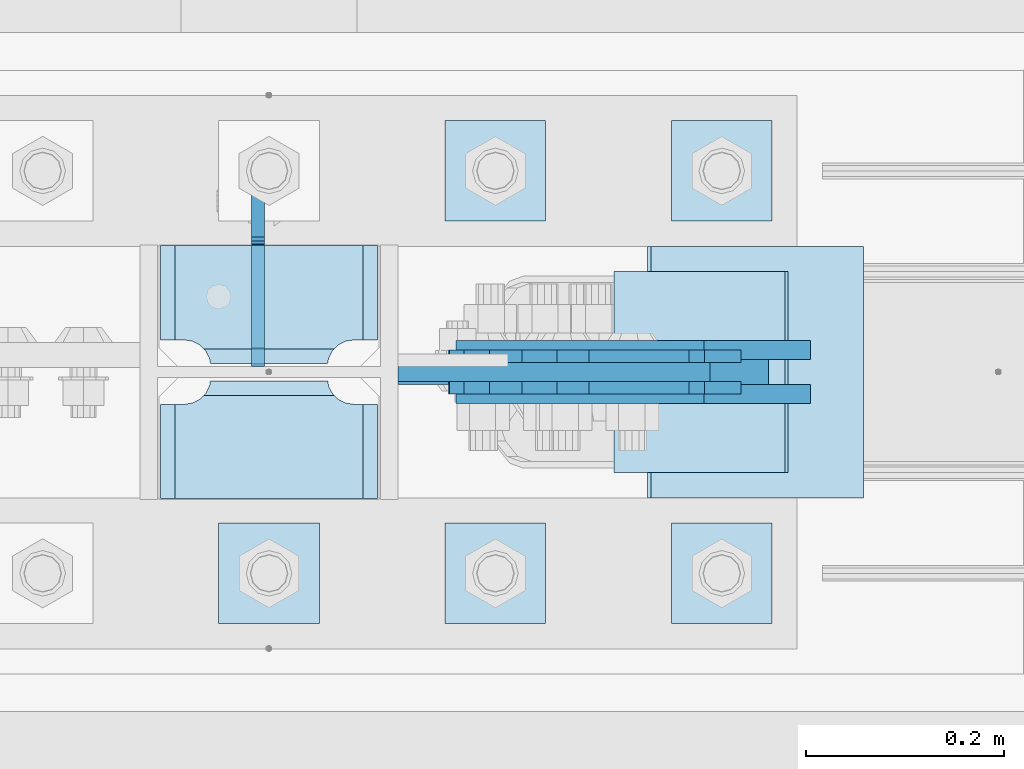
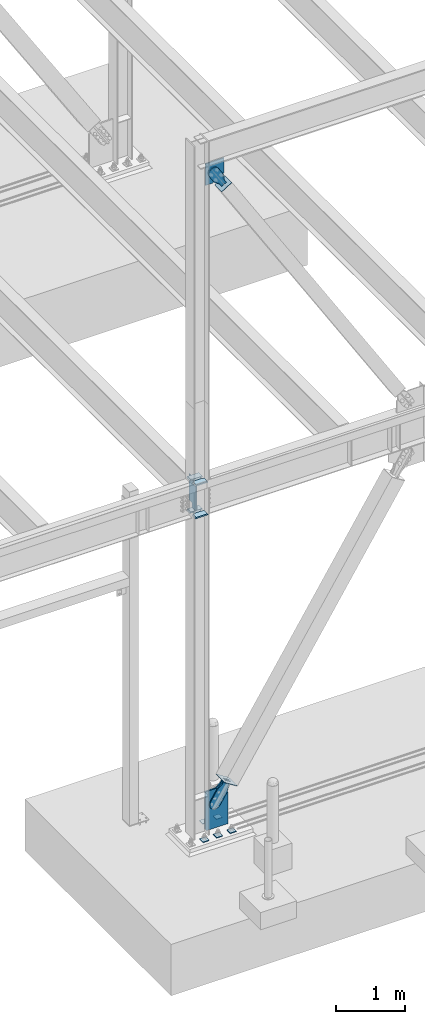
# One storey, part 3382 of 3843: 18 plates, 9 elements without a shape of their own.
"""IFC2X3 building model written with IfcOpenShell, lengths in millimetres."""

from ifc_helpers import new_model, si_unit, frame, origin_with_axes, place, context, subcontext, project, spatial, faceted_brep, material, type_object, element, aggregate, save


model = new_model("IFC2X3")

# Units and contexts
model_context = context("Model", 3, precision=1e-05, world=origin_with_axes())
body_context = subcontext(model_context, "Body", "Model", "MODEL_VIEW")
ifc_project = project(units=[si_unit("LENGTHUNIT", "METRE", prefix="MILLI"), si_unit("AREAUNIT", "SQUARE_METRE"), si_unit("VOLUMEUNIT", "CUBIC_METRE"), si_unit("MASSUNIT", "GRAM", prefix="KILO"), si_unit("TIMEUNIT", "SECOND"), si_unit("PLANEANGLEUNIT", "RADIAN"), si_unit("SOLIDANGLEUNIT", "STERADIAN"), si_unit("THERMODYNAMICTEMPERATUREUNIT", "DEGREE_CELSIUS"), si_unit("LUMINOUSINTENSITYUNIT", "LUMEN")], contexts=[model_context])

# Site, building, storey
site_placement = place(None, origin_with_axes())
site = spatial("IfcSite", under=ifc_project, at=site_placement, CompositionType="ELEMENT")
building_placement = place(site_placement, origin_with_axes())
building = spatial("IfcBuilding", under=site, at=building_placement, Name="Undefined", CompositionType="ELEMENT")
storey_placement = place(building_placement, origin_with_axes())
storey = spatial("IfcBuildingStorey", under=building, at=storey_placement, Name="Undefined", CompositionType="ELEMENT", Elevation=0.0)

# Assembly, plates
assembly_1_placement = place(storey_placement, origin_with_axes())
assembly_1 = element("IfcElementAssembly", 1, at=assembly_1_placement, inside=storey, Name="COLUMN", AssemblyPlace="NOTDEFINED", PredefinedType="RIGID_FRAME")
ifc_material_1 = material(Name="STEEL/A572-50")
plate_type_1 = type_object("IfcPlateType", PredefinedType="NOTDEFINED")
plate_1_placement = place(assembly_1_placement, frame((22972.7125, 89243.69375, 35845.75), z_axis=(-1.0, 0.0, 0.0), x_axis=(0.0, -1.0, 0.0)))
plate_1 = element("IfcPlate", 2, at=plate_1_placement, type_object=plate_type_1, material=ifc_material_1, Name="PLATE", context=body_context, shape_type="Brep", body=[
    faceted_brep([(106.374645952202, 9.2764413265686, 48.8208447555226), (104.398053430486, 12.6999999999971, 46.8442522338009), (104.398053430486, 12.6999999999971, 178.580747766202), (106.374645952201, 9.2764413265686, 176.60415524448), (113.897904100067, -3.75422402399272, 172.770863755024), (119.062750047655, -12.6999999999971, 171.952832520255), (119.062750047655, -12.6999999999971, 53.4721674797474), (113.897904100067, -3.75422402399272, 52.6541362449789), (95.2500007629424, 12.6999999999971, 17.8401965694866), (95.2500007629424, -12.6999999999971, 3.17549995231093), (0.0, -12.6999999999971, 3.17549995231093), (0.0, 12.6999999999971, 17.8401965694866), (0.0, 12.6999999999971, 207.585803430502), (0.0, -12.6999999999971, 222.250500047678), (95.2500007629424, -12.6999999999971, 222.250500047678), (95.2500007629424, 12.6999999999971, 207.585803430502), (95.2500007629424, -12.6999999999971, 198.437500762942), (95.2500007629424, 12.6999999999971, 198.437500762942), (96.5708629920846, -12.6999999999971, 190.097904863011), (96.5708629920846, 12.6999999999971, 190.097904863011), (100.404154481541, -12.6999999999971, 182.574646715148), (100.404154481541, 12.6999999999971, 182.574646715148), (106.374645952208, -12.6999999999971, 176.60415524448), (113.897904100071, -12.6999999999971, 172.770863755024), (113.897904100071, -12.6999999999971, 52.6541362449789), (106.374645952208, -12.6999999999971, 48.8208447555226), (100.404154481541, -12.6999999999971, 42.8503532848626), (100.404154481541, 12.6999999999971, 42.8503532848626), (96.5708629920846, -12.6999999999971, 35.3270951369923), (96.5708629920846, 12.6999999999971, 35.3270951369923), (95.2500007629424, -12.6999999999971, 26.9874992370605), (95.2500007629424, 12.6999999999971, 26.9874992370605)], [[[0, 1, 2, 3, 4, 5, 6, 7]], [[8, 9, 10, 11]], [[12, 13, 14, 15]], [[11, 10, 13, 12]], [[16, 17, 15, 14]], [[16, 18, 19, 17]], [[18, 20, 21, 19]], [[21, 20, 22, 3, 2]], [[22, 23, 4, 3]], [[23, 5, 4]], [[24, 7, 6]], [[24, 25, 0, 7]], [[25, 26, 27, 1, 0]], [[26, 28, 29, 27]], [[28, 30, 31, 29]], [[31, 30, 9, 8]], [[27, 29, 31, 8, 11, 12, 15, 17, 19, 21, 2, 1]], [[9, 30, 28, 26, 25, 24, 6, 5, 23, 22, 20, 18, 16, 14, 13, 10]]]),
])
plate_2_placement = place(assembly_1_placement, frame((22972.7125, 89243.69375, 36423.6), z_axis=(-1.0, 0.0, 0.0), x_axis=(0.0, -1.0, 0.0)))
plate_2 = element("IfcPlate", 3, at=plate_2_placement, type_object=plate_type_1, material=ifc_material_1, Name="PLATE", context=body_context, shape_type="Brep", body=[
    faceted_brep([(106.374645952202, 9.2764413265686, 48.8208447555226), (104.398053430486, 12.6999999999971, 46.8442522338009), (104.398053430486, 12.6999999999971, 178.580747766202), (106.374645952201, 9.2764413265686, 176.60415524448), (113.897904100067, -3.75422402399272, 172.770863755024), (119.062750047655, -12.6999999999971, 171.952832520255), (119.062750047655, -12.6999999999971, 53.4721674797474), (113.897904100067, -3.75422402399272, 52.6541362449789), (95.2500007629424, 12.6999999999971, 17.8401965694866), (95.2500007629424, -12.6999999999971, 3.17549995231093), (0.0, -12.6999999999971, 3.17549995231093), (0.0, 12.6999999999971, 17.8401965694866), (0.0, 12.6999999999971, 207.585803430502), (0.0, -12.6999999999971, 222.250500047678), (95.2500007629424, -12.6999999999971, 222.250500047678), (95.2500007629424, 12.6999999999971, 207.585803430502), (95.2500007629424, -12.6999999999971, 198.437500762942), (95.2500007629424, 12.6999999999971, 198.437500762942), (96.5708629920846, -12.6999999999971, 190.097904863011), (96.5708629920846, 12.6999999999971, 190.097904863011), (100.404154481541, -12.6999999999971, 182.574646715148), (100.404154481541, 12.6999999999971, 182.574646715148), (106.374645952208, -12.6999999999971, 176.60415524448), (113.897904100071, -12.6999999999971, 172.770863755024), (113.897904100071, -12.6999999999971, 52.6541362449789), (106.374645952208, -12.6999999999971, 48.8208447555226), (100.404154481541, -12.6999999999971, 42.8503532848626), (100.404154481541, 12.6999999999971, 42.8503532848626), (96.5708629920846, -12.6999999999971, 35.3270951369923), (96.5708629920846, 12.6999999999971, 35.3270951369923), (95.2500007629424, -12.6999999999971, 26.9874992370605), (95.2500007629424, 12.6999999999971, 26.9874992370605)], [[[0, 1, 2, 3, 4, 5, 6, 7]], [[8, 9, 10, 11]], [[12, 13, 14, 15]], [[11, 10, 13, 12]], [[16, 17, 15, 14]], [[16, 18, 19, 17]], [[18, 20, 21, 19]], [[21, 20, 22, 3, 2]], [[22, 23, 4, 3]], [[23, 5, 4]], [[24, 7, 6]], [[24, 25, 0, 7]], [[25, 26, 27, 1, 0]], [[26, 28, 29, 27]], [[28, 30, 31, 29]], [[31, 30, 9, 8]], [[27, 29, 31, 8, 11, 12, 15, 17, 19, 21, 2, 1]], [[9, 30, 28, 26, 25, 24, 6, 5, 23, 22, 20, 18, 16, 14, 13, 10]]]),
])
plate_3_placement = place(assembly_1_placement, frame((22972.7125, 89110.34375, 35845.75), z_axis=(-1.0, 0.0, 0.0), x_axis=(0.0, -1.0, 0.0)))
plate_3 = element("IfcPlate", 4, at=plate_3_placement, type_object=plate_type_1, material=ifc_material_1, Name="PLATE", context=body_context, shape_type="Brep", body=[
    faceted_brep([(15.8628540477987, 9.2764413265686, 176.60415524448), (17.8394465694582, 12.6999999999971, 178.580747766144), (17.8394465694582, 12.6999999999971, 46.8442522338592), (15.8628540477985, 9.2764413265686, 48.8208447555226), (8.33959589993262, -3.75422402399272, 52.6541362449789), (3.17474995228986, -12.6999999999971, 53.4721674797547), (3.17474995228986, -12.6999999999971, 171.952832520248), (8.33959589993288, -3.75422402399272, 172.770863755024), (122.237500000527, 12.6999999999971, 17.8401965694902), (122.23750000009, -12.6999999999971, 3.17549995231457), (26.9874992371479, -12.6999999999971, 3.17549995231457), (26.9874992375844, 12.6999999999971, 17.8401965694902), (26.9874992430996, 12.6999999999971, 207.585803430506), (26.9874992435361, -12.6999999999971, 222.250500047681), (122.237500006479, -12.6999999999971, 222.250500047681), (122.237500006042, 12.6999999999971, 207.585803430506), (8.33959589993174, -12.6999999999971, 172.770863755024), (15.8628540477948, -12.6999999999971, 176.60415524448), (21.833345518462, -12.6999999999971, 182.574646715148), (21.833345518462, 12.6999999999971, 182.574646715148), (25.6666370079183, -12.6999999999971, 190.097904863011), (25.6666370079183, 12.6999999999971, 190.097904863011), (26.9874992370605, -12.6999999999971, 198.437500762942), (26.9874992370605, 12.6999999999971, 198.437500762942), (26.9874992370605, -12.6999999999971, 26.9874992370605), (26.9874992370605, 12.6999999999971, 26.9874992370605), (25.6666370079183, -12.6999999999971, 35.3270951369923), (25.6666370079183, 12.6999999999971, 35.3270951369923), (21.833345518462, -12.6999999999971, 42.8503532848626), (21.833345518462, 12.6999999999971, 42.8503532848626), (15.8628540477948, -12.6999999999971, 48.8208447555226), (8.33959589993174, -12.6999999999971, 52.6541362449789)], [[[0, 1, 2, 3, 4, 5, 6, 7]], [[8, 9, 10, 11]], [[12, 13, 14, 15]], [[16, 7, 6]], [[16, 17, 0, 7]], [[17, 18, 19, 1, 0]], [[18, 20, 21, 19]], [[20, 22, 23, 21]], [[23, 22, 13, 12]], [[9, 8, 15, 14]], [[24, 25, 11, 10]], [[24, 26, 27, 25]], [[26, 28, 29, 27]], [[29, 28, 30, 3, 2]], [[30, 31, 4, 3]], [[31, 5, 4]], [[19, 21, 23, 12, 15, 8, 11, 25, 27, 29, 2, 1]], [[31, 30, 28, 26, 24, 10, 9, 14, 13, 22, 20, 18, 17, 16, 6, 5]]]),
])
plate_4_placement = place(assembly_1_placement, frame((22972.7125, 89110.34375, 36423.6), z_axis=(-1.0, 0.0, 0.0), x_axis=(0.0, -1.0, 0.0)))
plate_4 = element("IfcPlate", 5, at=plate_4_placement, type_object=plate_type_1, material=ifc_material_1, Name="PLATE", context=body_context, shape_type="Brep", body=[
    faceted_brep([(15.8628540477987, 9.2764413265686, 176.60415524448), (17.8394465694582, 12.6999999999971, 178.580747766144), (17.8394465694582, 12.6999999999971, 46.8442522338592), (15.8628540477985, 9.2764413265686, 48.8208447555226), (8.33959589993262, -3.75422402399272, 52.6541362449789), (3.17474995228986, -12.6999999999971, 53.4721674797547), (3.17474995228986, -12.6999999999971, 171.952832520248), (8.33959589993288, -3.75422402399272, 172.770863755024), (122.237500000527, 12.6999999999971, 17.8401965694902), (122.23750000009, -12.6999999999971, 3.17549995231457), (26.9874992371479, -12.6999999999971, 3.17549995231457), (26.9874992375844, 12.6999999999971, 17.8401965694902), (26.9874992430996, 12.6999999999971, 207.585803430506), (26.9874992435361, -12.6999999999971, 222.250500047681), (122.237500006479, -12.6999999999971, 222.250500047681), (122.237500006042, 12.6999999999971, 207.585803430506), (8.33959589993174, -12.6999999999971, 172.770863755024), (15.8628540477948, -12.6999999999971, 176.60415524448), (21.833345518462, -12.6999999999971, 182.574646715148), (21.833345518462, 12.6999999999971, 182.574646715148), (25.6666370079183, -12.6999999999971, 190.097904863011), (25.6666370079183, 12.6999999999971, 190.097904863011), (26.9874992370605, -12.6999999999971, 198.437500762942), (26.9874992370605, 12.6999999999971, 198.437500762942), (26.9874992370605, -12.6999999999971, 26.9874992370605), (26.9874992370605, 12.6999999999971, 26.9874992370605), (25.6666370079183, -12.6999999999971, 35.3270951369923), (25.6666370079183, 12.6999999999971, 35.3270951369923), (21.833345518462, -12.6999999999971, 42.8503532848626), (21.833345518462, 12.6999999999971, 42.8503532848626), (15.8628540477948, -12.6999999999971, 48.8208447555226), (8.33959589993174, -12.6999999999971, 52.6541362449789)], [[[0, 1, 2, 3, 4, 5, 6, 7]], [[8, 9, 10, 11]], [[12, 13, 14, 15]], [[16, 7, 6]], [[16, 17, 0, 7]], [[17, 18, 19, 1, 0]], [[18, 20, 21, 19]], [[20, 22, 23, 21]], [[23, 22, 13, 12]], [[9, 8, 15, 14]], [[24, 25, 11, 10]], [[24, 26, 27, 25]], [[26, 28, 29, 27]], [[29, 28, 30, 3, 2]], [[30, 31, 4, 3]], [[31, 5, 4]], [[19, 21, 23, 12, 15, 8, 11, 25, 27, 29, 2, 1]], [[31, 30, 28, 26, 24, 10, 9, 14, 13, 22, 20, 18, 17, 16, 6, 5]]]),
])

# Assembly, plate
assembly_2_placement = place(storey_placement, origin_with_axes())
assembly_2 = element("IfcElementAssembly", 6, at=assembly_2_placement, inside=storey, Name="CB", AssemblyPlace="NOTDEFINED", PredefinedType="RIGID_FRAME")
plate_type_2 = type_object("IfcPlateType", PredefinedType="NOTDEFINED")
plate_5_placement = place(assembly_2_placement, frame((23305.4642531047, 89115.9, 42002.075), z_axis=(0.0, 0.0, -1.0), x_axis=(-1.0, 0.0, 0.0)))
plate_5 = element("IfcPlate", 7, at=plate_5_placement, type_object=plate_type_2, material=ifc_material_1, Name="CB", context=body_context, shape_type="Brep", body=[
    faceted_brep([(0.0, -9.52500000000146, 0.0), (0.0, -9.52500000174041, 261.15819008874), (0.0, 9.52499999824795, 261.15819008874), (0.0, 9.52500000000146, 0.0), (196.587902692983, -9.52500000254076, 383.929714229205), (196.587902692983, 9.52499999746215, 383.929714229205), (315.289254935127, -9.52500000254076, 383.929714229205), (315.289254935127, 9.52499999746215, 383.929714229205), (315.289254935127, -9.52500000002328, -7.27595761418343e-12), (315.289254935127, 9.52499999996508, -7.27595761418343e-12)], [[[0, 1, 2, 3]], [[1, 4, 5, 2]], [[4, 6, 7, 5]], [[6, 8, 9, 7]], [[8, 0, 3, 9]], [[5, 7, 9, 3, 2]], [[8, 6, 4, 1, 0]]]),
])
aggregate(assembly_2, [plate_5])

assembly_3_placement = place(storey_placement, origin_with_axes())
assembly_3 = element("IfcElementAssembly", 8, at=assembly_3_placement, inside=storey, AssemblyPlace="NOTDEFINED", PredefinedType="RIGID_FRAME")
ifc_material_2 = material(Name="STEEL/A36")
plate_type_3 = type_object("IfcPlateType", PredefinedType="NOTDEFINED")
plate_6_placement = place(assembly_3_placement, frame((23299.8342060065, 89131.7750061035, 41617.6154840331), z_axis=(-0.848184242014813, 0.0, -0.529701323009256), x_axis=(0.529701323009257, 0.0, -0.848184242014813)))
plate_6 = element("IfcPlate", 9, at=plate_6_placement, type_object=plate_type_3, material=ifc_material_2, context=body_context, shape_type="Brep", body=[
    faceted_brep([(0.0, -6.3499999046162, 0.0), (-101.599999999482, -6.35000000000582, -44.6881937832222), (-101.599999999482, 6.35000000000582, -44.6881937832222), (7.27595761418343e-12, 6.3499999046162, 0.0), (-246.684985846376, -6.35000000000582, -44.6881937832586), (-246.684985846376, 6.35000000000582, -44.6881937832586), (-281.313054100305, -6.35000000000582, -37.8002427490646), (-281.313054100305, 6.35000000000582, -37.8002427490646), (-310.669312866783, -6.35000000000582, -18.18501775197), (-310.669312866783, 6.35000000000582, -18.18501775197), (-330.284537863758, -6.35000000000582, 11.1712410146756), (-330.284537863758, 6.35000000000582, 11.1712410146756), (-337.172488897893, -6.35000000000582, 45.7993031645856), (-337.172488897893, 6.35000000000582, 45.7993031645856), (-330.284537863699, -6.35000000000582, 80.4273714186893), (-330.284537863699, 6.35000000000582, 80.4273714186893), (-310.669312866681, -6.35000000000582, 109.783630185331), (-310.669312866681, 6.35000000000582, 109.783630185331), (-281.313054100174, -6.35000000000582, 129.39885518244), (-281.313054100174, 6.35000000000582, 129.39885518244), (-246.684988898312, -6.35000000000582, 136.286806216667), (-246.684988898312, 6.35000000000582, 136.286806216667), (-101.599999999322, -6.35000000000582, 136.286806216689), (-101.599999999322, 6.35000000000582, 136.286806216689), (2.18278728425503e-10, -6.35000000000582, 91.5986124321353), (2.18278728425503e-10, 6.35000000000582, 91.5986124321353), (69.8499999987471, -6.35000000000582, 91.598612432037), (69.8499999987471, 6.35000000000582, 91.598612432037), (69.8499999985434, -6.35000000000582, -8.73114913702011e-11), (69.8499999985434, 6.35000000000582, -8.73114913702011e-11)], [[[0, 1, 2, 3]], [[1, 4, 5, 2]], [[4, 6, 7, 5]], [[6, 8, 9, 7]], [[8, 10, 11, 9]], [[10, 12, 13, 11]], [[12, 14, 15, 13]], [[14, 16, 17, 15]], [[16, 18, 19, 17]], [[18, 20, 21, 19]], [[20, 22, 23, 21]], [[22, 24, 25, 23]], [[24, 26, 27, 25]], [[26, 28, 29, 27]], [[28, 0, 3, 29]], [[5, 7, 9, 11, 13, 15, 17, 19, 21, 23, 25, 27, 29, 3, 2]], [[28, 26, 24, 22, 20, 18, 16, 14, 12, 10, 8, 6, 4, 1, 0]]]),
])
aggregate(assembly_3, [plate_6])

assembly_4_placement = place(storey_placement, origin_with_axes())
assembly_4 = element("IfcElementAssembly", 10, at=assembly_4_placement, inside=storey, AssemblyPlace="NOTDEFINED", PredefinedType="RIGID_FRAME")
plate_7_placement = place(assembly_4_placement, frame((23299.8342060065, 89100.0250061035, 41617.6154840331), z_axis=(-0.848184242014813, 0.0, -0.529701323009256), x_axis=(0.529701323009257, 0.0, -0.848184242014813)))
plate_7 = element("IfcPlate", 11, at=plate_7_placement, type_object=plate_type_3, material=ifc_material_2, context=body_context, shape_type="Brep", body=[
    faceted_brep([(0.0, -6.3499999046162, 0.0), (-101.599999999482, -6.35000000000582, -44.6881937832222), (-101.599999999482, 6.35000000000582, -44.6881937832222), (7.27595761418343e-12, 6.3499999046162, 0.0), (-246.684985846376, -6.35000000000582, -44.6881937832586), (-246.684985846376, 6.35000000000582, -44.6881937832586), (-281.313054100305, -6.35000000000582, -37.8002427490646), (-281.313054100305, 6.35000000000582, -37.8002427490646), (-310.669312866783, -6.35000000000582, -18.18501775197), (-310.669312866783, 6.35000000000582, -18.18501775197), (-330.284537863758, -6.35000000000582, 11.1712410146756), (-330.284537863758, 6.35000000000582, 11.1712410146756), (-337.172488897893, -6.35000000000582, 45.7993031645856), (-337.172488897893, 6.35000000000582, 45.7993031645856), (-330.284537863699, -6.35000000000582, 80.4273714186893), (-330.284537863699, 6.35000000000582, 80.4273714186893), (-310.669312866681, -6.35000000000582, 109.783630185331), (-310.669312866681, 6.35000000000582, 109.783630185331), (-281.313054100174, -6.35000000000582, 129.39885518244), (-281.313054100174, 6.35000000000582, 129.39885518244), (-246.684988898312, -6.35000000000582, 136.286806216667), (-246.684988898312, 6.35000000000582, 136.286806216667), (-101.599999999322, -6.35000000000582, 136.286806216689), (-101.599999999322, 6.35000000000582, 136.286806216689), (2.18278728425503e-10, -6.35000000000582, 91.5986124321353), (2.18278728425503e-10, 6.35000000000582, 91.5986124321353), (69.8499999987471, -6.35000000000582, 91.598612432037), (69.8499999987471, 6.35000000000582, 91.598612432037), (69.8499999985434, -6.35000000000582, -8.73114913702011e-11), (69.8499999985434, 6.35000000000582, -8.73114913702011e-11)], [[[0, 1, 2, 3]], [[1, 4, 5, 2]], [[4, 6, 7, 5]], [[6, 8, 9, 7]], [[8, 10, 11, 9]], [[10, 12, 13, 11]], [[12, 14, 15, 13]], [[14, 16, 17, 15]], [[16, 18, 19, 17]], [[18, 20, 21, 19]], [[20, 22, 23, 21]], [[22, 24, 25, 23]], [[24, 26, 27, 25]], [[26, 28, 29, 27]], [[28, 0, 3, 29]], [[5, 7, 9, 11, 13, 15, 17, 19, 21, 23, 25, 27, 29, 3, 2]], [[28, 26, 24, 22, 20, 18, 16, 14, 12, 10, 8, 6, 4, 1, 0]]]),
])
aggregate(assembly_4, [plate_7])

assembly_5_placement = place(storey_placement, origin_with_axes())
assembly_5 = element("IfcElementAssembly", 12, at=assembly_5_placement, inside=storey, Name="Plate", AssemblyPlace="NOTDEFINED", PredefinedType="RIGID_FRAME")
plate_type_4 = type_object("IfcPlateType", PredefinedType="NOTDEFINED")
plate_8_placement = place(assembly_5_placement, frame((23210.1302731824, 89217.5000061035, 41482.9851923614), z_axis=(0.848184242014813, 0.0, 0.529701323009256), x_axis=(0.0, -1.0, 0.0)))
plate_8 = element("IfcPlate", 13, at=plate_8_placement, type_object=plate_type_4, material=ifc_material_2, Name="Plate", context=body_context, shape_type="Brep", body=[
    faceted_brep([(0.0, -3.17499999999927, 0.0), (0.0, -3.17500000043947, 203.200000001736), (0.0, 3.1749999995518, 203.200000001743), (0.0, 3.17499999999927, 0.0), (203.200000000012, -3.17500000043947, 203.200000001736), (203.200000000012, 3.1749999995518, 203.200000001743), (203.199996948242, -3.17499999999927, 0.0), (203.199996948242, 3.17499999999927, 0.0)], [[[0, 1, 2, 3]], [[1, 4, 5, 2]], [[4, 6, 7, 5]], [[6, 0, 3, 7]], [[5, 7, 3, 2]], [[6, 4, 1, 0]]]),
])
aggregate(assembly_5, [plate_8])

# Assembly, plates
assembly_6_placement = place(storey_placement, origin_with_axes())
assembly_6 = element("IfcElementAssembly", 14, at=assembly_6_placement, inside=storey, Name="TEMPLATE", AssemblyPlace="NOTDEFINED", PredefinedType="RIGID_FRAME")
plate_type_5 = type_object("IfcPlateType", PredefinedType="NOTDEFINED")
plate_9_placement = place(assembly_6_placement, frame((23266.4, 88963.5, 30130.75), z_axis=(0.0, -1.0, 0.0), x_axis=(1.0, 0.0, 0.0)))
plate_9 = element("IfcPlate", 15, at=plate_9_placement, type_object=plate_type_5, material=ifc_material_1, Name="Washer Plate", context=body_context, shape_type="Brep", body=[
    faceted_brep([(0.0, -6.3499999046162, 0.0), (-1.67347025126219e-10, -6.35000000000582, 101.600000000151), (-1.67347025126219e-10, 6.35000000000582, 101.600000000151), (7.27595761418343e-12, 6.3499999046162, 0.0), (101.599998474121, -6.34999999999854, 101.599998474121), (101.599998474121, 6.34999999999854, 101.599998474121), (101.6, -6.34999999999854, 0.0), (101.6, 6.34999999999854, 0.0)], [[[0, 1, 2, 3]], [[1, 4, 5, 2]], [[4, 6, 7, 5]], [[6, 0, 3, 7]], [[5, 7, 3, 2]], [[6, 4, 1, 0]]]),
])
plate_10_placement = place(assembly_6_placement, frame((23266.4, 89369.9, 30130.75), z_axis=(0.0, -1.0, 0.0), x_axis=(1.0, 0.0, 0.0)))
plate_10 = element("IfcPlate", 16, at=plate_10_placement, type_object=plate_type_5, material=ifc_material_1, Name="Washer Plate", context=body_context, shape_type="Brep", body=[
    faceted_brep([(0.0, -6.3499999046162, 0.0), (-1.67347025126219e-10, -6.35000000000582, 101.600000000151), (-1.67347025126219e-10, 6.35000000000582, 101.600000000151), (7.27595761418343e-12, 6.3499999046162, 0.0), (101.599998474121, -6.34999999999854, 101.599998474121), (101.599998474121, 6.34999999999854, 101.599998474121), (101.6, -6.34999999999854, 0.0), (101.6, 6.34999999999854, 0.0)], [[[0, 1, 2, 3]], [[1, 4, 5, 2]], [[4, 6, 7, 5]], [[6, 0, 3, 7]], [[5, 7, 3, 2]], [[6, 4, 1, 0]]]),
])
plate_11_placement = place(assembly_6_placement, frame((23037.8, 88963.5, 30130.75), z_axis=(0.0, -1.0, 0.0), x_axis=(1.0, 0.0, 0.0)))
plate_11 = element("IfcPlate", 17, at=plate_11_placement, type_object=plate_type_5, material=ifc_material_1, Name="Washer Plate", context=body_context, shape_type="Brep", body=[
    faceted_brep([(0.0, -6.3499999046162, 0.0), (-1.67347025126219e-10, -6.35000000000582, 101.600000000151), (-1.67347025126219e-10, 6.35000000000582, 101.600000000151), (7.27595761418343e-12, 6.3499999046162, 0.0), (101.599998474121, -6.34999999999854, 101.599998474121), (101.599998474121, 6.34999999999854, 101.599998474121), (101.6, -6.34999999999854, 0.0), (101.6, 6.34999999999854, 0.0)], [[[0, 1, 2, 3]], [[1, 4, 5, 2]], [[4, 6, 7, 5]], [[6, 0, 3, 7]], [[5, 7, 3, 2]], [[6, 4, 1, 0]]]),
])
plate_12_placement = place(assembly_6_placement, frame((23037.8, 89369.9, 30130.75), z_axis=(0.0, -1.0, 0.0), x_axis=(1.0, 0.0, 0.0)))
plate_12 = element("IfcPlate", 18, at=plate_12_placement, type_object=plate_type_5, material=ifc_material_1, Name="Washer Plate", context=body_context, shape_type="Brep", body=[
    faceted_brep([(0.0, -6.3499999046162, 0.0), (-1.67347025126219e-10, -6.35000000000582, 101.600000000151), (-1.67347025126219e-10, 6.35000000000582, 101.600000000151), (7.27595761418343e-12, 6.3499999046162, 0.0), (101.599998474121, -6.34999999999854, 101.599998474121), (101.599998474121, 6.34999999999854, 101.599998474121), (101.6, -6.34999999999854, 0.0), (101.6, 6.34999999999854, 0.0)], [[[0, 1, 2, 3]], [[1, 4, 5, 2]], [[4, 6, 7, 5]], [[6, 0, 3, 7]], [[5, 7, 3, 2]], [[6, 4, 1, 0]]]),
])
plate_13_placement = place(assembly_6_placement, frame((22809.2, 88963.5, 30130.75), z_axis=(0.0, -1.0, 0.0), x_axis=(1.0, 0.0, 0.0)))
plate_13 = element("IfcPlate", 19, at=plate_13_placement, type_object=plate_type_5, material=ifc_material_1, Name="Washer Plate", context=body_context, shape_type="Brep", body=[
    faceted_brep([(0.0, -6.3499999046162, 0.0), (-1.67347025126219e-10, -6.35000000000582, 101.600000000151), (-1.67347025126219e-10, 6.35000000000582, 101.600000000151), (7.27595761418343e-12, 6.3499999046162, 0.0), (101.599998474121, -6.34999999999854, 101.599998474121), (101.599998474121, 6.34999999999854, 101.599998474121), (101.6, -6.34999999999854, 0.0), (101.6, 6.34999999999854, 0.0)], [[[0, 1, 2, 3]], [[1, 4, 5, 2]], [[4, 6, 7, 5]], [[6, 0, 3, 7]], [[5, 7, 3, 2]], [[6, 4, 1, 0]]]),
])
aggregate(assembly_6, [plate_9, plate_10, plate_11, plate_12, plate_13])

# Plate
plate_type_6 = type_object("IfcPlateType", PredefinedType="NOTDEFINED")
plate_14_placement = place(assembly_1_placement, frame((22990.175, 89115.9, 30124.4), z_axis=(0.0, 0.0, 1.0), x_axis=(1.0, 0.0, 0.0)))
plate_14 = element("IfcPlate", 20, at=plate_14_placement, type_object=plate_type_6, material=ifc_material_1, Name="CB", context=body_context, shape_type="Brep", body=[
    faceted_brep([(0.0, -12.6999999999971, 19.0499992370605), (0.0, -12.6999999999971, 698.302890680108), (0.0, 12.6999999999971, 698.302890680108), (0.0, 12.6999999999971, 19.0499992370605), (167.760511938497, -12.6999999999971, 698.302890680108), (167.760511938497, 12.6999999999971, 698.302890680108), (374.243401923715, -12.6999999999971, 567.410408969536), (374.243401923715, 12.6999999999971, 567.410408969536), (374.243401923715, -12.6999999999971, 0.0), (374.243401923715, 12.6999999999971, 0.0), (19.0500015258731, -12.6999999999971, -6.33008312433958e-10), (19.0500015258731, 12.6999999999971, 0.0)], [[[0, 1, 2, 3]], [[1, 4, 5, 2]], [[4, 6, 7, 5]], [[6, 8, 9, 7]], [[8, 10, 11, 9]], [[10, 0, 3, 11]], [[5, 7, 9, 11, 3, 2]], [[10, 8, 6, 4, 1, 0]]]),
])

# Assembly, plate
assembly_7_placement = place(storey_placement, origin_with_axes())
assembly_7 = element("IfcElementAssembly", 21, at=assembly_7_placement, inside=storey, AssemblyPlace="NOTDEFINED", PredefinedType="RIGID_FRAME")
plate_type_7 = type_object("IfcPlateType", PredefinedType="NOTDEFINED")
plate_15_placement = place(assembly_7_placement, frame((23369.2169246553, 89138.1250061035, 30809.0625911752), z_axis=(-0.844597156660866, 0.0, 0.535402318785024), x_axis=(0.535402318785024, 0.0, 0.844597156660866)))
plate_15 = element("IfcPlate", 22, at=plate_15_placement, type_object=plate_type_7, material=ifc_material_2, context=body_context, shape_type="Brep", body=[
    faceted_brep([(0.0, -9.52500000000146, 0.0), (-101.599999996755, -9.52499999999418, -33.324272213511), (-101.599999996755, 9.52499999999418, -33.324272213511), (0.0, 9.52500000000146, 0.0), (-320.279297653902, -9.52499999999418, -33.3242722122595), (-320.279297653902, 9.52499999999418, -33.3242722122595), (-357.337405119242, -9.52499999999418, -25.9529563255783), (-357.337405119242, 9.52499999999418, -25.9529563255783), (-388.753751655597, -9.52499999999418, -4.96122468852991), (-388.753751655597, 9.52499999999418, -4.96122468852991), (-409.745483292782, -9.52499999999418, 26.4551218477136), (-409.745483292782, 9.52499999999418, 26.4551218477136), (-417.116799179586, -9.52499999999418, 63.5132262653569), (-417.116799179586, 9.52499999999418, 63.5132262653569), (-409.745483293211, -9.52499999999418, 100.57133373119), (-409.745483293211, 9.52499999999418, 100.57133373119), (-388.753751656006, -9.52499999999418, 131.987680267928), (-388.753751656006, 9.52499999999418, 131.987680267928), (-357.337405119271, -9.52499999999418, 152.97941190518), (-357.337405119271, 9.52499999999418, 152.97941190518), (-320.279299183247, -9.52499999999418, 160.350727791658), (-320.279299183247, 9.52499999999418, 160.350727791658), (-101.599999998418, -9.52499999999418, 160.350727790414), (-101.599999998418, 9.52499999999418, 160.350727790414), (-1.04046193882823e-09, -9.52499999999418, 127.02645557576), (-1.04046193882823e-09, 9.52499999999418, 127.02645557576), (69.8499999968899, -9.52499999999418, 127.026455575353), (69.8499999968899, 9.52499999999418, 127.026455575353), (69.8499999979995, -9.52499999999418, -4.00177668780088e-10), (69.8499999979995, 9.52499999999418, -4.00177668780088e-10)], [[[0, 1, 2, 3]], [[1, 4, 5, 2]], [[4, 6, 7, 5]], [[6, 8, 9, 7]], [[8, 10, 11, 9]], [[10, 12, 13, 11]], [[12, 14, 15, 13]], [[14, 16, 17, 15]], [[16, 18, 19, 17]], [[18, 20, 21, 19]], [[20, 22, 23, 21]], [[22, 24, 25, 23]], [[24, 26, 27, 25]], [[26, 28, 29, 27]], [[28, 0, 3, 29]], [[5, 7, 9, 11, 13, 15, 17, 19, 21, 23, 25, 27, 29, 3, 2]], [[28, 26, 24, 22, 20, 18, 16, 14, 12, 10, 8, 6, 4, 1, 0]]]),
])
aggregate(assembly_7, [plate_15])

assembly_8_placement = place(storey_placement, origin_with_axes())
assembly_8 = element("IfcElementAssembly", 23, at=assembly_8_placement, inside=storey, AssemblyPlace="NOTDEFINED", PredefinedType="RIGID_FRAME")
plate_16_placement = place(assembly_8_placement, frame((23369.2169246553, 89093.6750061035, 30809.0625911752), z_axis=(-0.844597156660866, 0.0, 0.535402318785024), x_axis=(0.535402318785024, 0.0, 0.844597156660866)))
plate_16 = element("IfcPlate", 24, at=plate_16_placement, type_object=plate_type_7, material=ifc_material_2, context=body_context, shape_type="Brep", body=[
    faceted_brep([(0.0, -9.52500000000146, 0.0), (-101.599999996755, -9.52499999999418, -33.324272213511), (-101.599999996755, 9.52499999999418, -33.324272213511), (0.0, 9.52500000000146, 0.0), (-320.279297653902, -9.52499999999418, -33.3242722122595), (-320.279297653902, 9.52499999999418, -33.3242722122595), (-357.337405119242, -9.52499999999418, -25.9529563255783), (-357.337405119242, 9.52499999999418, -25.9529563255783), (-388.753751655597, -9.52499999999418, -4.96122468852991), (-388.753751655597, 9.52499999999418, -4.96122468852991), (-409.745483292782, -9.52499999999418, 26.4551218477136), (-409.745483292782, 9.52499999999418, 26.4551218477136), (-417.116799179586, -9.52499999999418, 63.5132262653569), (-417.116799179586, 9.52499999999418, 63.5132262653569), (-409.745483293211, -9.52499999999418, 100.57133373119), (-409.745483293211, 9.52499999999418, 100.57133373119), (-388.753751656006, -9.52499999999418, 131.987680267928), (-388.753751656006, 9.52499999999418, 131.987680267928), (-357.337405119271, -9.52499999999418, 152.97941190518), (-357.337405119271, 9.52499999999418, 152.97941190518), (-320.279299183247, -9.52499999999418, 160.350727791658), (-320.279299183247, 9.52499999999418, 160.350727791658), (-101.599999998418, -9.52499999999418, 160.350727790414), (-101.599999998418, 9.52499999999418, 160.350727790414), (-1.04046193882823e-09, -9.52499999999418, 127.02645557576), (-1.04046193882823e-09, 9.52499999999418, 127.02645557576), (69.8499999968899, -9.52499999999418, 127.026455575353), (69.8499999968899, 9.52499999999418, 127.026455575353), (69.8499999979995, -9.52499999999418, -4.00177668780088e-10), (69.8499999979995, 9.52499999999418, -4.00177668780088e-10)], [[[0, 1, 2, 3]], [[1, 4, 5, 2]], [[4, 6, 7, 5]], [[6, 8, 9, 7]], [[8, 10, 11, 9]], [[10, 12, 13, 11]], [[12, 14, 15, 13]], [[14, 16, 17, 15]], [[16, 18, 19, 17]], [[18, 20, 21, 19]], [[20, 22, 23, 21]], [[22, 24, 25, 23]], [[24, 26, 27, 25]], [[26, 28, 29, 27]], [[28, 0, 3, 29]], [[5, 7, 9, 11, 13, 15, 17, 19, 21, 23, 25, 27, 29, 3, 2]], [[28, 26, 24, 22, 20, 18, 16, 14, 12, 10, 8, 6, 4, 1, 0]]]),
])
aggregate(assembly_8, [plate_16])

assembly_9_placement = place(storey_placement, origin_with_axes())
assembly_9 = element("IfcElementAssembly", 25, at=assembly_9_placement, inside=storey, Name="Plate", AssemblyPlace="NOTDEFINED", PredefinedType="RIGID_FRAME")
plate_type_8 = type_object("IfcPlateType", PredefinedType="NOTDEFINED")
plate_17_placement = place(assembly_9_placement, frame((23458.5356214929, 88988.9000061035, 30831.3851415845), z_axis=(-0.844597156660866, 0.0, 0.535402318785024), x_axis=(0.0, 1.0, 0.0)))
plate_17 = element("IfcPlate", 26, at=plate_17_placement, type_object=plate_type_8, material=ifc_material_2, Name="Plate", context=body_context, shape_type="Brep", body=[
    faceted_brep([(0.0, -3.17499999999927, 0.0), (0.0, -3.17499999965185, 254.000000005151), (0.0, 3.17500000035216, 254.000000005166), (0.0, 3.17499999999927, 0.0), (254.0, -3.17499999965185, 254.000000005151), (254.0, 3.17500000035216, 254.000000005166), (254.0, -3.17500000000291, 0.0), (254.0, 3.17499999999927, 1.45519152283669e-11)], [[[0, 1, 2, 3]], [[1, 4, 5, 2]], [[4, 6, 7, 5]], [[6, 0, 3, 7]], [[5, 7, 3, 2]], [[6, 4, 1, 0]]]),
])
aggregate(assembly_9, [plate_17])

# Plate
plate_type_9 = type_object("IfcPlateType", PredefinedType="NOTDEFINED")
plate_18_placement = place(assembly_1_placement, frame((22848.8874999046, 89121.45625, 35877.5), z_axis=(0.0, 0.707106781186548, 0.707106781186548), x_axis=(5.70000238222118e-08, 0.707106781186546, -0.707106781186546)))
plate_18 = element("IfcPlate", 27, at=plate_18_placement, type_object=plate_type_9, material=ifc_material_1, Name="PLATE", context=body_context, shape_type="Brep", body=[
    faceted_brep([(0.0, -6.3499999046162, 0.0), (-363.700372901621, -6.34999999999854, 363.700372901469), (-363.700372901621, 6.34999999999854, 363.700372901469), (7.27595761418343e-12, 6.3499999046162, 0.0), (-363.700372901338, -6.34999999999854, 390.641141264845), (-363.700372901338, 6.34999999999854, 390.641141264845), (-290.174525774113, -6.34999999999854, 464.166988122408), (-290.174525774113, 6.34999999999854, 464.166988122408), (-286.054349305959, -6.34999999999854, 461.413974221941), (-286.054349305959, 6.34999999999854, 461.413974221941), (-281.194269787906, -6.34999999999854, 460.447244299372), (-281.194269787906, 6.34999999999854, 460.447244299372), (-276.334190269838, -6.34999999999854, 461.413974222), (-276.334190269838, 6.34999999999854, 461.413974222), (-272.214013801662, -6.34999999999854, 464.16698812251), (-272.214013801662, 6.34999999999854, 464.16698812251), (-218.332476939475, -6.34999999999854, 518.048524984726), (-218.332476939475, 6.34999999999854, 518.048524984726), (104.956743417526, -6.34999999999854, 194.759304627849), (104.956743417526, 6.34999999999854, 194.759304627849), (51.0752065553315, -6.34999999999854, 140.877767765633), (51.0752065553315, 6.34999999999854, 140.877767765633), (48.3221926548213, -6.34999999999854, 136.757591297457), (48.3221926548213, 6.34999999999854, 136.757591297457), (47.3554627322083, -6.34999999999854, 131.897511779389), (47.3554627322083, 6.34999999999854, 131.897511779389), (48.3221926547776, -6.34999999999854, 127.037432261335), (48.3221926547776, 6.34999999999854, 127.037432261335), (51.0752065552297, -6.34999999999854, 122.917255793189), (51.0752065552297, 6.34999999999854, 122.917255793189), (100.466615355741, -6.34999999999854, 73.5258469927066), (100.466615355741, 6.34999999999854, 73.5258469927066), (26.9407683632217, -6.34999999999854, 1.30967237055302e-10), (26.9407683632217, 6.34999999999854, 1.30967237055302e-10)], [[[0, 1, 2, 3]], [[1, 4, 5, 2]], [[4, 6, 7, 5]], [[6, 8, 9, 7]], [[8, 10, 11, 9]], [[10, 12, 13, 11]], [[12, 14, 15, 13]], [[14, 16, 17, 15]], [[16, 18, 19, 17]], [[18, 20, 21, 19]], [[20, 22, 23, 21]], [[22, 24, 25, 23]], [[24, 26, 27, 25]], [[26, 28, 29, 27]], [[28, 30, 31, 29]], [[30, 32, 33, 31]], [[32, 0, 3, 33]], [[5, 7, 9, 11, 13, 15, 17, 19, 21, 23, 25, 27, 29, 31, 33, 3, 2]], [[32, 30, 28, 26, 24, 22, 20, 18, 16, 14, 12, 10, 8, 6, 4, 1, 0]]]),
])

aggregate(assembly_1, [plate_14, plate_18, plate_1, plate_2, plate_3, plate_4])

save(model, "model.ifc")
